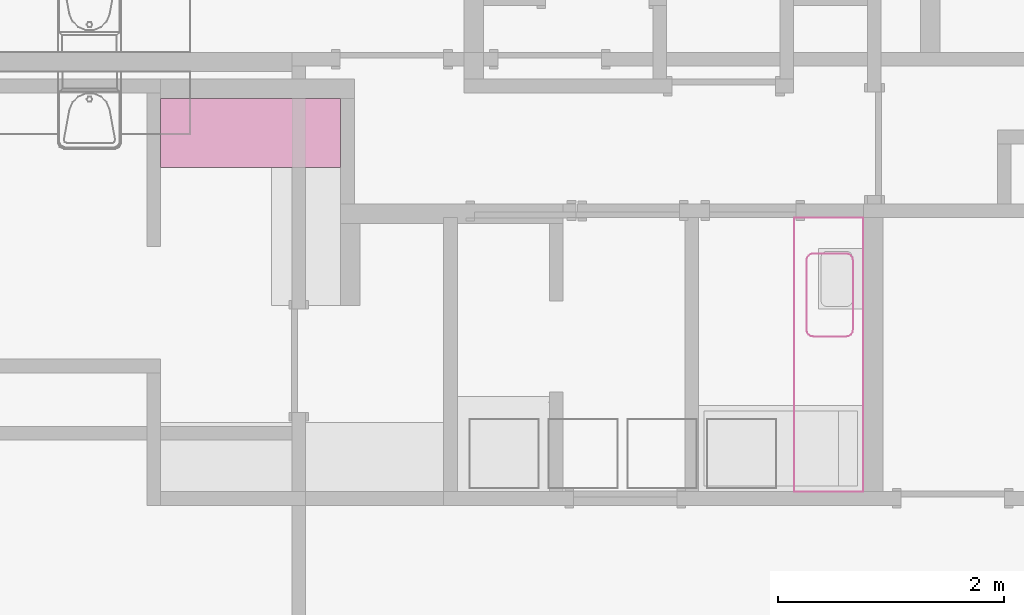
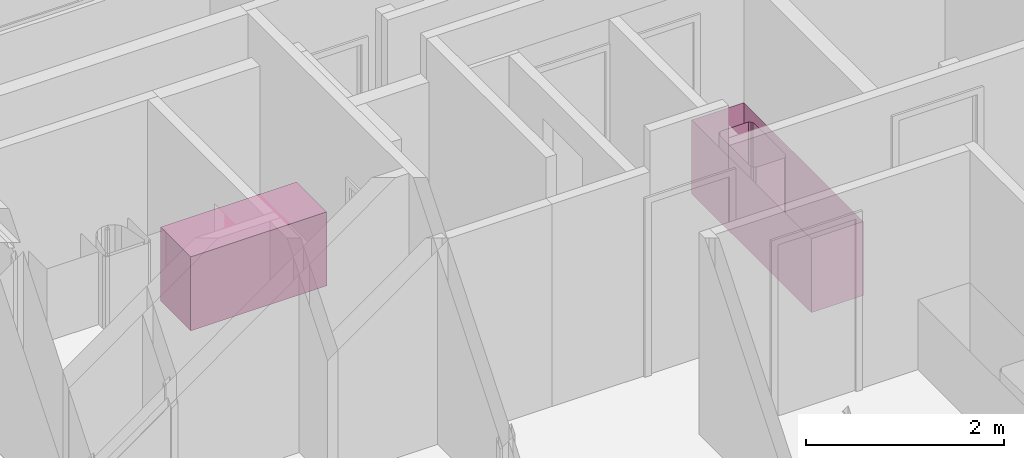
# One storey, part 31 of 64: 3 furniture elements, 1 element without a shape of its own.
"""IFC4 building model written with IfcOpenShell, lengths in feet."""

from ifc_helpers import new_model, entity, si_unit, converted_unit, frame, origin_with_axes, origin_2d_with_axis, place, context, subcontext, project, spatial, polygons, element, aggregate, save


model = new_model("IFC4")

# Units and contexts
model_context = context("Model", 3, precision=1e-05, world=origin_with_axes())
plan_context = context("Plan", 2, precision=1e-05, world=origin_2d_with_axis())
context_of_model_1 = context(None, 3, precision=1e-05, world=origin_with_axes())
context_of_model_2 = context(None, 3, precision=1e-05, world=origin_with_axes())
body_context = subcontext(model_context, "Body", "Model", "MODEL_VIEW")
ifc_project = project(units=[converted_unit("PLANEANGLEUNIT", "degree", entity("IfcReal", 0.0174532925199433), si_unit("PLANEANGLEUNIT", "RADIAN"), dimensions=[0, 0, 0, 0, 0, 0, 0]), converted_unit("AREAUNIT", "square foot", entity("IfcReal", 0.09290304), si_unit("AREAUNIT", "SQUARE_METRE"), dimensions=[2, 0, 0, 0, 0, 0, 0]), converted_unit("LENGTHUNIT", "foot", entity("IfcReal", 0.3048), si_unit("LENGTHUNIT", "METRE"), dimensions=[1, 0, 0, 0, 0, 0, 0]), converted_unit("VOLUMEUNIT", "cubic foot", entity("IfcReal", 0.0283168467116885), si_unit("VOLUMEUNIT", "CUBIC_METRE"), dimensions=[3, 0, 0, 0, 0, 0, 0])], contexts=[model_context, plan_context, context_of_model_1, context_of_model_2])

# Site, building, storey
site_placement = place(None, origin_with_axes())
site = spatial("IfcSite", under=ifc_project, at=site_placement)
building_placement = place(site_placement, origin_with_axes())
building = spatial("IfcBuilding", under=site, at=building_placement, Name="Building")
storey_placement = place(building_placement, origin_with_axes())
storey = spatial("IfcBuildingStorey", under=building, at=storey_placement, Name="Storey")

# Assembly, furniture
assembly_placement = place(storey_placement, origin_with_axes())
assembly = element("IfcElementAssembly", 1, at=assembly_placement, inside=storey, Name="Assembly")
furniture_1_placement = place(assembly_placement, frame((-288.889251668935, 22.0215868136388, 1.95553296507187e-07), z_axis=(0.0, 0.0, 1.0), x_axis=(5.52335052361657e-07, -0.999999999999847, 0.0)))
furniture_1 = element("IfcFurniture", 2, at=furniture_1_placement, Name="Cabinet-Kitchen", PredefinedType="NOTDEFINED", context=body_context, shape_type="Tessellation", body=[
    polygons([(1.99999570846558, 5.21948671340942, 0.0), (1.99999570846558, 5.21948671340942, 2.83333349227905), (2.00000071525574, 7.03991872796905e-06, 0.0), (2.00000071525574, 7.03991872796905e-06, 2.83333349227905), (5.86659893997421e-07, 6.6488119045971e-06, 0.0), (-4.39029372500954e-06, 5.21948671340942, 0.0), (-4.39029372500954e-06, 5.21948671340942, 2.83333349227905), (5.86659893997421e-07, 6.6488119045971e-06, 2.83333349227905), (1.6817582945805e-05, 5.86659916734789e-06, 2.99999976158142), (2.0000147819519, 5.08438552060397e-06, 2.99999976158142), (1.84894433914451e-05, 5.21948671340942, 2.99999976158142), (2.00001645088196, 5.21948671340942, 2.99999976158142), (5.86659893997421e-07, 6.6488119045971e-06, 2.83333349227905), (-4.39029372500954e-06, 5.21948671340942, 2.83333349227905), (2.00000071525574, 7.03991872796905e-06, 2.83333349227905), (1.99999570846558, 5.21948671340942, 2.83333349227905)], [[[4, 2, 1]], [[4, 1, 3]], [[7, 5, 6]], [[7, 8, 5]], [[1, 5, 3]], [[1, 6, 5]], [[2, 4, 8]], [[7, 2, 8]], [[3, 8, 4]], [[3, 5, 8]], [[1, 2, 7]], [[1, 7, 6]]]),
    polygons([(1.99999570846558, 5.21948671340942, 0.0), (1.99999570846558, 5.21948671340942, 2.83333349227905), (2.00000071525574, 7.03991872796905e-06, 0.0), (2.00000071525574, 7.03991872796905e-06, 2.83333349227905), (5.86659893997421e-07, 6.6488119045971e-06, 0.0), (-4.39029372500954e-06, 5.21948671340942, 0.0), (-4.39029372500954e-06, 5.21948671340942, 2.83333349227905), (5.86659893997421e-07, 6.6488119045971e-06, 2.83333349227905), (1.6817582945805e-05, 5.86659916734789e-06, 2.99999976158142), (2.0000147819519, 5.08438552060397e-06, 2.99999976158142), (1.84894433914451e-05, 5.21948671340942, 2.99999976158142), (2.00001645088196, 5.21948671340942, 2.99999976158142), (5.86659893997421e-07, 6.6488119045971e-06, 2.83333349227905), (-4.39029372500954e-06, 5.21948671340942, 2.83333349227905), (2.00000071525574, 7.03991872796905e-06, 2.83333349227905), (1.99999570846558, 5.21948671340942, 2.83333349227905)], [[[11, 10, 9]], [[11, 12, 10]], [[16, 14, 13]], [[16, 13, 15]], [[13, 14, 11]], [[9, 13, 11]], [[15, 10, 12]], [[15, 12, 16]], [[16, 12, 11]], [[16, 11, 14]], [[15, 13, 9]], [[10, 15, 9]]]),
])
furniture_2_placement = place(assembly_placement, frame((-288.889251668935, 22.0215883780652, 1.95553296507187e-07), z_axis=(0.0, 0.0, 1.0), x_axis=(5.52335052361657e-07, -0.999999999999847, 0.0)))
furniture_2 = element("IfcFurniture", 3, at=furniture_2_placement, Name="Cabinet-Kitchen", PredefinedType="NOTDEFINED", context=body_context, shape_type="Tessellation", body=[
    polygons([(1.99999570846558, 5.21948671340942, 0.0), (1.99999570846558, 5.21948671340942, 2.83333349227905), (2.00000071525574, 7.03991872796905e-06, 0.0), (2.00000071525574, 7.03991872796905e-06, 2.83333349227905), (5.86659893997421e-07, 6.6488119045971e-06, 0.0), (-4.39029372500954e-06, 5.21948671340942, 0.0), (-4.39029372500954e-06, 5.21948671340942, 2.83333349227905), (5.86659893997421e-07, 6.6488119045971e-06, 2.83333349227905), (1.6817582945805e-05, 5.86659916734789e-06, 2.99999976158142), (2.0000147819519, 5.08438552060397e-06, 2.99999976158142), (1.84894433914451e-05, 5.21948671340942, 2.99999976158142), (2.00001645088196, 5.21948671340942, 2.99999976158142), (5.86659893997421e-07, 6.6488119045971e-06, 2.83333349227905), (-4.39029372500954e-06, 5.21948671340942, 2.83333349227905), (2.00000071525574, 7.03991872796905e-06, 2.83333349227905), (1.99999570846558, 5.21948671340942, 2.83333349227905)], [[[4, 2, 1]], [[4, 1, 3]], [[7, 5, 6]], [[7, 8, 5]], [[1, 5, 3]], [[1, 6, 5]], [[2, 4, 8]], [[7, 2, 8]], [[3, 8, 4]], [[3, 5, 8]], [[1, 2, 7]], [[1, 7, 6]]]),
    polygons([(1.99999570846558, 5.21948671340942, 0.0), (1.99999570846558, 5.21948671340942, 2.83333349227905), (2.00000071525574, 7.03991872796905e-06, 0.0), (2.00000071525574, 7.03991872796905e-06, 2.83333349227905), (5.86659893997421e-07, 6.6488119045971e-06, 0.0), (-4.39029372500954e-06, 5.21948671340942, 0.0), (-4.39029372500954e-06, 5.21948671340942, 2.83333349227905), (5.86659893997421e-07, 6.6488119045971e-06, 2.83333349227905), (1.6817582945805e-05, 5.86659916734789e-06, 2.99999976158142), (2.0000147819519, 5.08438552060397e-06, 2.99999976158142), (1.84894433914451e-05, 5.21948671340942, 2.99999976158142), (2.00001645088196, 5.21948671340942, 2.99999976158142), (5.86659893997421e-07, 6.6488119045971e-06, 2.83333349227905), (-4.39029372500954e-06, 5.21948671340942, 2.83333349227905), (2.00000071525574, 7.03991872796905e-06, 2.83333349227905), (1.99999570846558, 5.21948671340942, 2.83333349227905)], [[[11, 10, 9]], [[11, 12, 10]], [[16, 14, 13]], [[16, 13, 15]], [[13, 14, 11]], [[9, 13, 11]], [[15, 10, 12]], [[15, 12, 16]], [[16, 12, 11]], [[16, 11, 14]], [[15, 13, 9]], [[10, 15, 9]]]),
])
aggregate(assembly, [furniture_1, furniture_2])

# Furniture
furniture_3_placement = place(storey_placement, frame((-268.517366544468, 18.5724099477132, 3.91106593014374e-07), z_axis=(0.0, 0.0, 1.0), x_axis=(1.0, 0.0, 0.0)))
element("IfcFurniture", 4, at=furniture_3_placement, inside=storey, Name="Plane", PredefinedType="NOTDEFINED", context=body_context, shape_type="Tessellation", body=[
    polygons([(-0.503472983837128, -3.44833993911743, 0.0), (-0.503472983837128, -3.44833993911743, 2.99999952316284), (-0.424950897693634, -3.43272066116333, 0.0), (-0.424950897693634, -3.43272066116333, 2.99999952316284), (-0.424950808286667, -1.05728328227997, 0.0), (-0.424950808286667, -1.05728328227997, 2.99999952316284), (-0.503473103046417, -1.04166376590729, 0.0), (-0.503473103046417, -1.04166376590729, 2.99999952316284), (-0.358368426561356, -3.38824415206909, 0.0), (-0.358368426561356, -3.38824415206909, 2.99999952316284), (-1.99997556209564, -7.94169807434082, 0.0), (-1.99997556209564, -7.94169807434082, 2.99999952316284), (0.0, -7.94169807434082, 0.0), (0.0, -7.94169807434082, 2.99999952316284), (-1.44478797912598, -1.04166388511658, 0.0), (-1.44478797912598, -1.04166388511658, 2.99999952316284), (-0.313863545656204, -3.32167148590088, 0.0), (-0.313863545656204, -3.32167148590088, 2.99999952316284), (-1.64999186992645, -3.2431468963623, 0.0), (-1.64999186992645, -3.2431468963623, 2.99999952316284), (-1.63437259197235, -3.32167148590088, 0.0), (-1.63437259197235, -3.32167148590088, 2.99999952316284), (-1.52328515052795, -1.05728352069855, 0.0), (-1.52328515052795, -1.05728352069855, 2.99999952316284), (-0.298269122838974, -3.24314665794373, 0.0), (-0.298269122838974, -3.24314665794373, 2.99999952316284), (-1.58989250659943, -3.38824415206909, 0.0), (-1.58989250659943, -3.38824415206909, 2.99999952316284), (-1.58989250659943, -1.10176920890808, 0.0), (-1.58989250659943, -1.10176920890808, 2.99999952316284), (0.0, 0.0, 0.0), (0.0, 0.0, 2.99999952316284), (-2.0, 0.0, 0.0), (-2.0, 0.0, 2.99999952316284), (-0.298269122838974, -1.2468603849411, 0.0), (-0.298269122838974, -1.2468603849411, 2.99999952316284), (-1.52328515052795, -3.43272066116333, 0.0), (-1.52328515052795, -3.43272066116333, 2.99999952316284), (-1.63437259197235, -1.16833865642548, 0.0), (-1.63437259197235, -1.16833865642548, 2.99999952316284), (-0.313863426446915, -1.16833865642548, 0.0), (-0.313863426446915, -1.16833865642548, 2.99999952316284), (-1.44478797912598, -3.44833993911743, 0.0), (-1.44478797912598, -3.44833993911743, 2.99999952316284), (-1.64999186992645, -1.24686074256897, 0.0), (-1.64999186992645, -1.24686074256897, 2.99999952316284), (-0.358368515968323, -1.10176920890808, 0.0), (-0.358368515968323, -1.10176920890808, 2.99999952316284)], [[[8, 6, 5, 7]], [[10, 4, 3, 9]], [[16, 8, 7, 15]], [[9, 17, 18, 10]], [[19, 21, 22, 20]], [[24, 16, 15, 23]], [[17, 25, 26, 18]], [[21, 27, 28, 22]], [[30, 24, 23, 29]], [[31, 32, 14, 13]], [[25, 35, 36, 26]], [[29, 39, 40, 30]], [[13, 14, 12, 11]], [[35, 41, 42, 36]], [[19, 20, 46, 45]], [[44, 38, 37, 43]], [[39, 45, 46, 40]], [[41, 47, 48, 42]], [[33, 34, 32, 31]], [[6, 48, 47, 5]], [[38, 28, 27, 37]], [[12, 34, 33, 11]], [[2, 44, 43, 1]], [[4, 2, 1, 3]]], closed=False),
])

save(model, "model.ifc")
